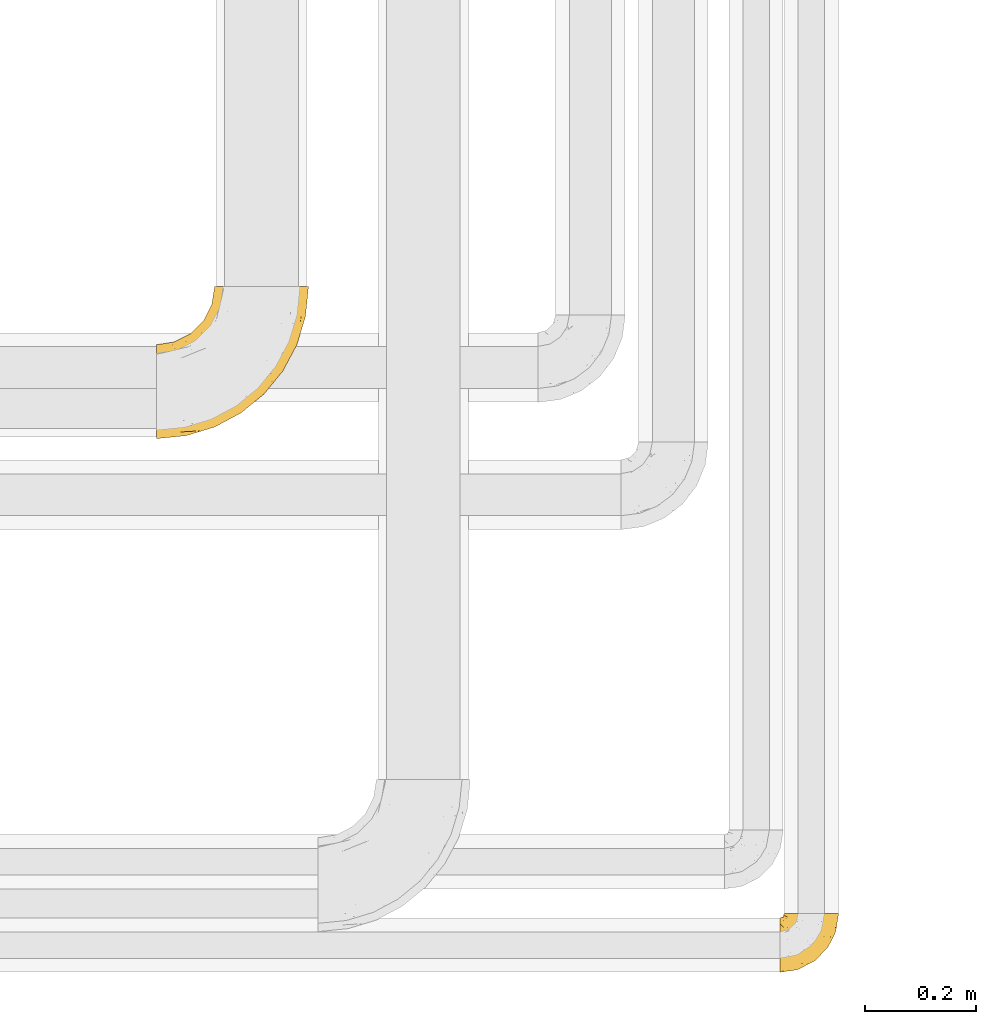
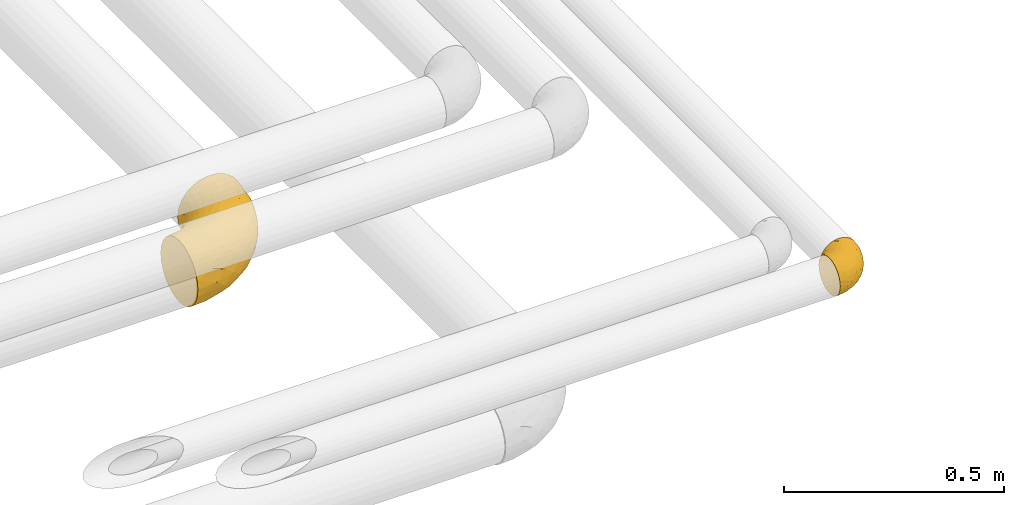
# One storey, part 487 of 827: 2 coverings.
"""IFC2X3 building model written with IfcOpenShell, lengths in millimetres."""

from ifc_helpers import new_model, entity, si_unit, converted_unit, derived_unit, direction, frame, origin, place, context, subcontext, project, spatial, faceted_brep, element, save


model = new_model("IFC2X3")

# Units and contexts
model_context = context("Model", 3, precision=0.01, world=origin(), true_north=direction((6.12303176911189e-17, 1.0)))
body_context = subcontext(model_context, "Body", "Model", "MODEL_VIEW")
ifc_project = project(units=[si_unit("LENGTHUNIT", "METRE", prefix="MILLI"), si_unit("AREAUNIT", "SQUARE_METRE"), si_unit("VOLUMEUNIT", "CUBIC_METRE"), converted_unit("PLANEANGLEUNIT", "DEGREE", entity("IfcRatioMeasure", 0.0174532925199433), si_unit("PLANEANGLEUNIT", "RADIAN"), dimensions=[0, 0, 0, 0, 0, 0, 0]), si_unit("MASSUNIT", "GRAM", prefix="KILO"), derived_unit("MASSDENSITYUNIT", [(si_unit("MASSUNIT", "GRAM", prefix="KILO"), 1), (si_unit("LENGTHUNIT", "METRE"), -3)]), derived_unit("MOMENTOFINERTIAUNIT", [(si_unit("LENGTHUNIT", "METRE"), 4)]), si_unit("TIMEUNIT", "SECOND"), si_unit("FREQUENCYUNIT", "HERTZ"), si_unit("THERMODYNAMICTEMPERATUREUNIT", "DEGREE_CELSIUS"), derived_unit("THERMALTRANSMITTANCEUNIT", [(si_unit("MASSUNIT", "GRAM", prefix="KILO"), 1), (si_unit("THERMODYNAMICTEMPERATUREUNIT", "KELVIN"), -1), (si_unit("TIMEUNIT", "SECOND"), -3)]), derived_unit("VOLUMETRICFLOWRATEUNIT", [(si_unit("LENGTHUNIT", "METRE"), 3), (si_unit("TIMEUNIT", "SECOND"), -1)]), derived_unit("MASSFLOWRATEUNIT", [(si_unit("MASSUNIT", "GRAM", prefix="KILO"), 1), (si_unit("TIMEUNIT", "SECOND"), -1)]), derived_unit("ROTATIONALFREQUENCYUNIT", [(si_unit("TIMEUNIT", "SECOND"), -1)]), si_unit("ELECTRICCURRENTUNIT", "AMPERE"), si_unit("ELECTRICVOLTAGEUNIT", "VOLT"), si_unit("POWERUNIT", "WATT"), si_unit("FORCEUNIT", "NEWTON", prefix="KILO"), si_unit("ILLUMINANCEUNIT", "LUX"), si_unit("LUMINOUSFLUXUNIT", "LUMEN"), si_unit("LUMINOUSINTENSITYUNIT", "CANDELA"), derived_unit("USERDEFINED", [(si_unit("MASSUNIT", "GRAM", prefix="KILO"), -1), (si_unit("LENGTHUNIT", "METRE"), -2), (si_unit("TIMEUNIT", "SECOND"), 3), (si_unit("LUMINOUSFLUXUNIT", "LUMEN"), 1)]), derived_unit("LINEARVELOCITYUNIT", [(si_unit("LENGTHUNIT", "METRE"), 1), (si_unit("TIMEUNIT", "SECOND"), -1)]), si_unit("PRESSUREUNIT", "PASCAL"), derived_unit("USERDEFINED", [(si_unit("LENGTHUNIT", "METRE"), -2), (si_unit("MASSUNIT", "GRAM", prefix="KILO"), 1), (si_unit("TIMEUNIT", "SECOND"), -2)]), derived_unit("LINEARFORCEUNIT", [(si_unit("MASSUNIT", "GRAM", prefix="KILO"), 1), (si_unit("LENGTHUNIT", "METRE"), 1), (si_unit("TIMEUNIT", "SECOND"), -2), (si_unit("LENGTHUNIT", "METRE"), -1)]), derived_unit("PLANARFORCEUNIT", [(si_unit("MASSUNIT", "GRAM", prefix="KILO"), 1), (si_unit("LENGTHUNIT", "METRE"), 1), (si_unit("TIMEUNIT", "SECOND"), -2), (si_unit("LENGTHUNIT", "METRE"), -2)])], contexts=[model_context])

# Site, building, storey
site_placement = place(None, origin())
site = spatial("IfcSite", under=ifc_project, at=site_placement, CompositionType="ELEMENT")
building_placement = place(site_placement, origin())
building = spatial("IfcBuilding", under=site, at=building_placement, CompositionType="ELEMENT")
storey_placement = place(building_placement, frame((0.0, 0.0, 28200.0)))
storey = spatial("IfcBuildingStorey", under=building, at=storey_placement, Name="08", CompositionType="ELEMENT", Elevation=28200.0)

# Coverings
covering_1_placement = place(storey_placement, frame((61094.04, 6214.96, 3049.25)))
element("IfcCovering", 1, at=covering_1_placement, inside=storey, Name=":ADSK_", ObjectType=":ADSK_", PredefinedType="INSULATION", context=body_context, shape_type="Brep", body=[
    faceted_brep([(58.6, 107.75, 99.9), (69.54, 107.75, 98.66), (79.93, 107.75, 95.02), (89.25, 107.75, 89.17), (97.03, 107.75, 81.38), (102.88, 107.75, 72.06), (106.51, 107.75, 61.68), (107.75, 107.75, 50.75), (106.51, 107.75, 39.8), (102.87, 107.75, 29.41), (97.02, 107.75, 20.09), (89.23, 107.75, 12.31), (79.91, 107.75, 6.46), (69.53, 107.75, 2.83), (58.6, 107.75, 1.6), (52.89, 107.75, 2.24), (47.65, 107.75, 2.83), (42.46, 107.75, 4.65), (37.26, 107.75, 6.47), (27.94, 107.75, 12.32), (20.16, 107.75, 20.11), (14.31, 107.75, 29.43), (10.68, 107.75, 39.81), (9.45, 107.75, 50.75), (10.68, 107.75, 61.69), (14.32, 107.75, 72.08), (20.17, 107.75, 81.4), (27.96, 107.75, 89.18), (37.28, 107.75, 95.03), (42.47, 107.75, 96.85), (47.66, 107.75, 98.66), (52.89, 107.75, 99.25), (55.75, 107.75, 99.57), (1.6, 98.22, 38.02), (1.6, 93.31, 26.17), (1.6, 89.4, 21.08), (1.6, 85.5, 15.99), (1.6, 80.41, 12.09), (1.6, 75.32, 8.18), (1.6, 69.39, 5.73), (1.6, 63.47, 3.27), (1.6, 56.48, 2.35), (1.6, 53.61, 1.97), (1.6, 50.75, 1.6), (1.6, 38.02, 3.27), (1.6, 26.17, 8.18), (1.6, 15.99, 15.99), (1.6, 8.18, 26.17), (1.6, 3.27, 38.02), (1.6, 1.6, 50.75), (1.6, 3.27, 63.47), (1.6, 8.18, 75.32), (1.6, 15.99, 85.5), (1.6, 26.17, 93.31), (1.6, 38.02, 98.22), (1.6, 50.75, 99.9), (1.6, 56.48, 99.14), (1.6, 63.47, 98.22), (1.6, 69.39, 95.77), (1.6, 75.32, 93.31), (1.6, 80.41, 89.4), (1.6, 85.5, 85.5), (1.6, 89.4, 80.41), (1.6, 93.31, 75.32), (1.6, 98.22, 63.47), (1.6, 99.9, 50.75), (69.96, 27.53, 59.31), (59.59, 25.32, 73.08), (51.96, 16.29, 63.72), (34.4, 6.79, 50.75), (23.37, 4.51, 58.64), (13.68, 3.51, 50.75), (41.52, 17.47, 76.74), (26.26, 7.6, 67.68), (20.18, 12.27, 78.92), (72.33, 70.89, 94.31), (65.88, 87.17, 98.76), (57.55, 67.3, 98.4), (23.76, 31.65, 94.57), (46.5, 33.58, 89.91), (46.57, 47.23, 96.32), (21.17, 43.26, 98.79), (23.41, 55.08, 99.9), (17.92, 53.99, 99.9), (12.43, 52.9, 99.9), (9.72, 52.36, 99.9), (7.01, 51.82, 99.9), (26.77, 21.5, 87.31), (76.59, 89.94, 95.61), (95.55, 60.45, 60.43), (102.57, 83.0, 65.24), (92.89, 64.79, 72.87), (54.26, 85.93, 99.9), (51.17, 81.31, 99.9), (48.08, 76.69, 99.9), (44.99, 72.06, 99.9), (41.9, 67.44, 99.9), (85.16, 88.74, 90.65), (85.97, 45.98, 63.14), (59.58, 47.13, 91.89), (99.5, 89.4, 75.25), (105.83, 95.66, 50.75), (53.59, 28.5, 82.18), (67.0, 42.81, 85.08), (71.56, 38.28, 76.93), (87.47, 45.35, 50.75), (75.73, 33.61, 50.75), (92.24, 82.57, 83.02), (58.06, 105.04, 99.9), (57.52, 102.33, 99.9), (56.44, 96.91, 99.9), (55.35, 91.42, 99.9), (81.33, 65.92, 87.13), (80.35, 53.11, 80.85), (39.44, 54.37, 99.17), (102.55, 74.94, 50.75), (37.28, 64.35, 99.9), (32.65, 61.26, 99.9), (28.03, 58.17, 99.9), (63.99, 21.87, 50.75), (74.55, 34.79, 67.61), (83.62, 48.48, 72.25), (95.01, 60.15, 50.75), (49.19, 14.33, 50.75), (46.96, 99.07, 98.69), (8.77, 60.55, 99.01), (18.28, 64.18, 98.79), (11.68, 64.36, 98.29), (11.79, 103.17, 68.51), (15.69, 101.69, 76.82), (42.49, 87.75, 98.54), (47.41, 89.38, 99.3), (7.94, 88.34, 83.57), (9.27, 82.14, 89.47), (7.98, 94.51, 75.76), (13.4, 89.64, 84.86), (13.04, 98.41, 75.89), (7.36, 99.71, 64.77), (23.46, 89.37, 90.83), (30.46, 88.21, 94.62), (26.54, 95.2, 90.37), (6.76, 79.14, 91.18), (26.46, 101.22, 88.65), (20.77, 99.41, 84.11), (20.68, 84.72, 91.75), (40.26, 97.47, 96.86), (7.15, 102.19, 50.75), (9.28, 104.02, 58.97), (38.78, 82.66, 98.37), (18.27, 95.42, 83.91), (31.78, 78.67, 97.52), (12.75, 72.69, 95.55), (22.96, 66.46, 98.76), (17.55, 75.3, 95.26), (27.63, 72.74, 98.04), (15.23, 82.93, 90.65), (33.25, 99.27, 93.51), (32.43, 93.51, 94.16), (27.9, 67.35, 99.1), (7.97, 94.51, 25.73), (15.22, 82.94, 10.84), (7.93, 88.33, 17.92), (13.38, 89.64, 16.64), (13.12, 103.62, 30.44), (42.49, 87.74, 2.95), (47.4, 89.38, 2.19), (51.17, 81.31, 1.6), (40.24, 97.47, 4.63), (20.76, 99.41, 17.39), (12.43, 52.9, 1.6), (7.01, 51.82, 1.6), (4.31, 51.28, 1.6), (26.44, 101.21, 12.86), (26.52, 95.19, 11.13), (11.68, 64.36, 3.2), (12.75, 72.69, 5.94), (9.27, 82.13, 12.02), (17.55, 75.3, 6.23), (6.76, 79.14, 10.31), (33.21, 99.28, 8.0), (32.41, 93.51, 7.34), (8.77, 60.55, 2.48), (22.96, 66.46, 2.73), (18.48, 63.96, 2.64), (56.44, 96.91, 1.6), (46.95, 99.06, 2.8), (7.36, 99.7, 36.71), (17.92, 53.99, 1.6), (23.41, 55.08, 1.6), (9.85, 103.3, 38.59), (57.52, 102.33, 1.6), (56.98, 99.62, 1.6), (48.08, 76.69, 1.6), (38.78, 82.66, 3.12), (18.25, 95.42, 17.59), (44.99, 72.06, 1.6), (31.74, 78.68, 3.98), (30.45, 88.2, 6.87), (27.63, 72.75, 3.45), (20.65, 84.74, 9.76), (55.35, 91.42, 1.6), (54.26, 85.93, 1.6), (13.03, 98.41, 25.62), (23.44, 89.37, 10.67), (27.9, 67.35, 2.39), (32.65, 61.26, 1.6), (28.03, 58.17, 1.6), (37.28, 64.35, 1.6), (41.9, 67.44, 1.6), (39.74, 54.08, 2.4), (23.37, 4.51, 42.85), (26.77, 21.5, 14.18), (46.18, 33.43, 11.56), (53.54, 28.5, 19.27), (41.53, 17.47, 24.75), (59.61, 25.36, 28.37), (76.79, 90.18, 5.95), (66.11, 86.97, 2.79), (21.17, 43.26, 2.71), (51.96, 16.29, 37.78), (26.26, 7.6, 33.81), (20.18, 12.27, 22.57), (23.76, 31.65, 6.92), (92.88, 64.79, 28.61), (102.57, 83.0, 36.24), (95.54, 60.44, 41.05), (71.63, 38.35, 24.55), (74.55, 34.8, 33.88), (72.51, 71.54, 7.11), (69.96, 27.53, 42.18), (92.23, 82.57, 18.46), (85.15, 88.74, 10.84), (80.45, 53.19, 20.69), (83.65, 48.49, 29.27), (57.57, 67.28, 3.1), (63.68, 52.32, 9.18), (85.95, 45.94, 38.38), (99.49, 89.4, 26.23), (81.23, 65.75, 14.34), (47.07, 46.73, 5.46), (66.99, 42.82, 16.39)], [[[0, 1, 2, 3, 4, 5, 6, 7, 8, 9, 10, 11, 12, 13, 14, 15, 16, 17, 18, 19, 20, 21, 22, 23, 24, 25, 26, 27, 28, 29, 30, 31, 32]], [[33, 34, 35, 36, 37, 38, 39, 40, 41, 42, 43, 44, 45, 46, 47, 48, 49, 50, 51, 52, 53, 54, 55, 56, 57, 58, 59, 60, 61, 62, 63, 64, 65]], [[66, 67, 68]], [[69, 70, 71]], [[68, 72, 73]], [[73, 72, 74]], [[75, 76, 77]], [[78, 79, 80]], [[51, 50, 73]], [[81, 82, 83, 84, 85, 86, 55]], [[52, 87, 53]], [[74, 52, 51]], [[2, 1, 88]], [[89, 90, 91]], [[77, 92, 93, 94, 95, 96]], [[55, 54, 81]], [[78, 53, 87]], [[5, 90, 6]], [[88, 76, 75]], [[97, 3, 2]], [[89, 91, 98]], [[99, 80, 79]], [[90, 5, 100]], [[74, 87, 52]], [[100, 5, 4]], [[90, 101, 6]], [[79, 102, 103]], [[102, 67, 104]], [[105, 98, 106]], [[107, 4, 3]], [[76, 0, 108, 109, 110, 111, 92]], [[107, 112, 113]], [[114, 77, 96]], [[89, 115, 90]], [[114, 96, 116, 117, 118, 82]], [[75, 97, 88]], [[119, 66, 68]], [[50, 71, 70]], [[100, 91, 90]], [[99, 77, 80]], [[102, 104, 103]], [[97, 107, 3]], [[80, 81, 78]], [[107, 97, 112]], [[68, 73, 70]], [[66, 98, 120]], [[78, 81, 54]], [[114, 81, 80]], [[53, 78, 54]], [[78, 87, 79]], [[102, 87, 72]], [[79, 103, 99]], [[4, 107, 100]], [[91, 100, 107]], [[88, 97, 2]], [[112, 97, 75]], [[99, 112, 75]], [[103, 104, 113]], [[91, 121, 98]], [[89, 105, 122, 115]], [[101, 90, 115]], [[101, 7, 6]], [[88, 1, 76]], [[0, 76, 1]], [[92, 77, 76]], [[73, 74, 51]], [[87, 74, 72]], [[81, 114, 82]], [[77, 114, 80]], [[87, 102, 79]], [[67, 102, 72]], [[68, 67, 72]], [[67, 120, 104]], [[120, 121, 104]], [[104, 121, 113]], [[121, 120, 98]], [[91, 107, 113]], [[91, 113, 121]], [[103, 113, 112]], [[106, 98, 66]], [[105, 89, 98]], [[106, 66, 119]], [[67, 66, 120]], [[68, 69, 123, 119]], [[50, 49, 71]], [[50, 70, 73]], [[112, 99, 103]], [[77, 99, 75]], [[69, 68, 70]], [[29, 124, 110]], [[84, 83, 125]], [[126, 82, 118]], [[59, 58, 127]], [[25, 128, 129]], [[130, 93, 131]], [[132, 62, 133]], [[134, 135, 136]], [[137, 65, 64]], [[64, 134, 137]], [[138, 139, 140]], [[111, 110, 124, 92]], [[134, 136, 137]], [[134, 64, 63]], [[141, 61, 60]], [[125, 58, 57]], [[142, 143, 140]], [[142, 26, 143]], [[127, 83, 82]], [[28, 124, 29]], [[108, 0, 32, 31, 30, 110, 109]], [[30, 29, 110]], [[135, 144, 138]], [[28, 145, 124]], [[57, 56, 55, 86, 85, 84]], [[146, 147, 23]], [[24, 23, 147]], [[25, 143, 26]], [[95, 94, 148]], [[24, 128, 25]], [[149, 138, 143]], [[124, 145, 131]], [[127, 58, 125]], [[150, 148, 139]], [[127, 126, 151]], [[151, 59, 127]], [[152, 151, 126]], [[153, 154, 155]], [[153, 133, 141]], [[145, 28, 27]], [[142, 156, 27]], [[157, 148, 130]], [[61, 133, 62]], [[134, 132, 135]], [[147, 128, 24]], [[65, 137, 146]], [[146, 137, 147]], [[128, 137, 136]], [[137, 128, 147]], [[128, 136, 129]], [[149, 129, 136]], [[25, 129, 143]], [[158, 152, 117]], [[152, 118, 117]], [[153, 151, 152]], [[158, 116, 154]], [[144, 150, 138]], [[153, 152, 158]], [[133, 153, 155]], [[133, 155, 132]], [[60, 151, 141]], [[135, 132, 155]], [[134, 63, 132]], [[144, 135, 155]], [[135, 138, 149]], [[155, 154, 144]], [[150, 154, 96]], [[154, 150, 144]], [[148, 94, 130]], [[82, 126, 127]], [[118, 152, 126]], [[150, 96, 95]], [[139, 148, 157]], [[150, 95, 148]], [[93, 92, 131]], [[130, 145, 156]], [[130, 94, 93]], [[84, 125, 57]], [[127, 125, 83]], [[140, 139, 157]], [[150, 139, 138]], [[140, 157, 142]], [[138, 140, 143]], [[156, 142, 157]], [[27, 26, 142]], [[130, 156, 157]], [[145, 27, 156]], [[132, 63, 62]], [[124, 131, 92]], [[130, 131, 145]], [[129, 149, 143]], [[135, 149, 136]], [[141, 133, 61]], [[60, 59, 151]], [[141, 151, 153]], [[116, 96, 154]], [[153, 158, 154]], [[158, 117, 116]], [[34, 33, 159]], [[160, 161, 162]], [[22, 21, 163]], [[164, 165, 166]], [[19, 18, 167]], [[168, 21, 20]], [[42, 41, 40, 169, 170, 171, 43]], [[172, 173, 168]], [[174, 38, 175]], [[176, 177, 178]], [[179, 164, 180]], [[40, 181, 169]], [[182, 183, 175]], [[17, 184, 185]], [[65, 146, 186]], [[187, 174, 188]], [[23, 22, 189]], [[174, 39, 38]], [[15, 14, 190, 191, 184, 16]], [[181, 40, 39]], [[192, 193, 164]], [[194, 163, 168]], [[33, 186, 159]], [[180, 173, 172]], [[195, 196, 193]], [[18, 185, 167]], [[173, 180, 197]], [[198, 199, 196]], [[200, 201, 185, 184]], [[184, 17, 16]], [[18, 17, 185]], [[202, 159, 186]], [[194, 168, 203]], [[189, 163, 202]], [[204, 205, 182]], [[187, 181, 174]], [[160, 177, 176]], [[206, 183, 182]], [[206, 182, 205]], [[201, 165, 185]], [[165, 164, 167]], [[172, 179, 180]], [[202, 194, 162]], [[176, 161, 160]], [[65, 186, 33]], [[163, 189, 22]], [[175, 177, 182]], [[174, 183, 188]], [[177, 198, 204]], [[199, 160, 162]], [[198, 207, 204]], [[175, 38, 37]], [[198, 177, 160]], [[178, 177, 175]], [[176, 35, 161]], [[34, 159, 161]], [[162, 161, 159]], [[202, 162, 159]], [[199, 162, 203]], [[196, 199, 203]], [[198, 160, 199]], [[193, 197, 180]], [[208, 198, 196]], [[188, 183, 206]], [[175, 183, 174]], [[193, 192, 195]], [[195, 208, 196]], [[197, 196, 203]], [[180, 164, 193]], [[168, 163, 21]], [[166, 165, 201]], [[166, 192, 164]], [[189, 202, 186]], [[186, 146, 189]], [[23, 189, 146]], [[174, 181, 39]], [[169, 181, 187]], [[196, 197, 193]], [[173, 203, 168]], [[203, 173, 197]], [[172, 168, 20]], [[20, 19, 172]], [[179, 172, 19]], [[19, 167, 179]], [[164, 179, 167]], [[35, 176, 36]], [[35, 34, 161]], [[185, 165, 167]], [[162, 194, 203]], [[163, 194, 202]], [[176, 178, 36]], [[37, 36, 178]], [[175, 37, 178]], [[177, 204, 182]], [[207, 198, 208]], [[207, 205, 204]], [[209, 188, 206, 205, 207, 208]], [[48, 210, 71]], [[211, 212, 213]], [[214, 213, 215]], [[216, 217, 13]], [[218, 43, 171, 170, 169, 187, 188]], [[219, 220, 214]], [[47, 46, 221]], [[210, 48, 220]], [[211, 222, 212]], [[222, 45, 44]], [[221, 220, 47]], [[47, 220, 48]], [[221, 211, 214]], [[223, 224, 225]], [[211, 46, 45]], [[226, 227, 215]], [[43, 218, 44]], [[217, 216, 228]], [[219, 215, 229]], [[14, 13, 217]], [[224, 9, 8]], [[10, 230, 11]], [[11, 231, 12]], [[232, 223, 233]], [[234, 208, 195, 192, 166, 201]], [[235, 234, 228]], [[222, 44, 218]], [[106, 229, 236]], [[224, 237, 9]], [[231, 238, 228]], [[9, 237, 10]], [[115, 224, 101]], [[239, 234, 235]], [[231, 11, 230]], [[223, 230, 237]], [[224, 8, 101]], [[223, 236, 233]], [[225, 115, 122, 105]], [[216, 12, 231]], [[209, 234, 239]], [[210, 219, 69]], [[219, 214, 215]], [[229, 119, 219]], [[209, 218, 188]], [[239, 212, 222]], [[239, 222, 218]], [[45, 222, 211]], [[235, 212, 239]], [[213, 212, 240]], [[223, 237, 224]], [[230, 10, 237]], [[238, 231, 230]], [[216, 231, 228]], [[232, 230, 223]], [[235, 238, 240]], [[115, 225, 224]], [[233, 236, 227]], [[8, 7, 101]], [[234, 209, 208]], [[218, 209, 239]], [[217, 228, 234]], [[13, 12, 216]], [[234, 201, 217]], [[217, 201, 200, 184, 191, 190, 14]], [[211, 221, 46]], [[220, 221, 214]], [[71, 210, 69]], [[71, 49, 48]], [[219, 210, 220]], [[226, 215, 213]], [[211, 213, 214]], [[226, 213, 240]], [[215, 227, 229]], [[232, 240, 238]], [[233, 227, 226]], [[232, 233, 226]], [[236, 223, 225]], [[240, 232, 226]], [[232, 238, 230]], [[225, 105, 236]], [[236, 105, 106]], [[236, 229, 227]], [[123, 69, 219, 119]], [[106, 119, 229]], [[238, 235, 228]], [[212, 235, 240]]]),
])
covering_2_placement = place(storey_placement, frame((59966.95, 7179.76, 2813.52)))
element("IfcCovering", 2, at=covering_2_placement, inside=storey, Name=":ADSK_", ObjectType=":ADSK_", PredefinedType="INSULATION", context=body_context, shape_type="Brep", body=[
    faceted_brep([(220.62, 276.45, 166.18), (234.03, 276.45, 159.93), (246.14, 276.45, 151.44), (256.6, 276.45, 140.98), (265.08, 276.45, 128.87), (271.33, 276.45, 115.47), (275.16, 276.45, 101.18), (276.45, 276.45, 86.45), (275.16, 276.45, 71.71), (271.33, 276.45, 57.42), (265.08, 276.45, 44.02), (256.59, 276.45, 31.9), (246.13, 276.45, 21.45), (234.02, 276.45, 12.96), (220.62, 276.45, 6.71), (206.33, 276.45, 2.89), (191.6, 276.45, 1.6), (176.86, 276.45, 2.89), (162.57, 276.45, 6.71), (149.17, 276.45, 12.97), (137.05, 276.45, 21.45), (126.6, 276.45, 31.91), (118.11, 276.45, 44.02), (111.86, 276.45, 57.42), (108.04, 276.45, 71.71), (106.75, 276.45, 86.45), (108.04, 276.45, 101.18), (111.86, 276.45, 115.47), (118.12, 276.45, 128.88), (126.6, 276.45, 140.99), (137.06, 276.45, 151.45), (149.17, 276.45, 159.93), (162.57, 276.45, 166.18), (176.86, 276.45, 170.01), (191.6, 276.45, 171.3), (206.33, 276.45, 170.01), (1.6, 146.44, 26.45), (1.6, 128.87, 12.96), (1.6, 108.41, 4.49), (1.6, 86.45, 1.6), (1.6, 64.48, 4.49), (1.6, 44.02, 12.96), (1.6, 26.45, 26.45), (1.6, 12.96, 44.02), (1.6, 4.49, 64.48), (1.6, 1.6, 86.45), (1.6, 4.49, 108.41), (1.6, 12.96, 128.87), (1.6, 26.45, 146.44), (1.6, 44.02, 159.93), (1.6, 64.48, 168.4), (1.6, 86.45, 171.3), (1.6, 108.41, 168.4), (1.6, 128.87, 159.93), (1.6, 146.44, 146.44), (1.6, 159.93, 128.87), (1.6, 168.4, 108.41), (1.6, 171.3, 86.45), (1.6, 168.4, 64.48), (1.6, 159.93, 44.02), (78.36, 15.68, 108.89), (55.22, 6.88, 86.45), (106.78, 22.52, 86.45), (227.56, 227.06, 160.57), (210.93, 105.43, 113.84), (166.54, 74.07, 132.78), (169.48, 65.28, 115.35), (195.94, 82.1, 86.45), (121.35, 108.1, 169.66), (150.14, 157.98, 171.3), (135.1, 142.94, 171.3), (120.06, 127.9, 171.3), (124.32, 40.39, 124.06), (130.67, 36.41, 106.11), (210.57, 219.38, 167.01), (93.72, 48.08, 149.97), (139.64, 66.33, 145.0), (144.17, 85.3, 156.09), (154.29, 47.92, 86.45), (208.4, 119.45, 134.92), (240.3, 167.65, 130.81), (221.79, 158.93, 146.85), (230.13, 123.75, 86.45), (262.33, 215.32, 120.3), (248.26, 166.87, 114.99), (263.49, 198.48, 102.82), (63.94, 24.94, 135.66), (108.29, 42.19, 137.97), (79.35, 82.38, 169.13), (42.69, 36.25, 152.15), (271.16, 222.82, 86.45), (255.52, 171.26, 86.45), (76.62, 60.65, 162.08), (212.49, 178.29, 159.82), (49.07, 13.85, 122.41), (126.68, 91.93, 164.65), (177.19, 124.79, 160.16), (177.64, 100.4, 147.46), (179.24, 158.16, 168.0), (84.03, 105.26, 171.3), (172.78, 194.01, 171.3), (246.43, 215.15, 143.95), (43.87, 91.21, 171.3), (186.83, 234.17, 171.3), (35.25, 164.99, 128.7), (55.06, 177.54, 120.84), (29.98, 171.18, 111.79), (40.1, 114.41, 167.99), (174.11, 252.37, 169.81), (141.82, 215.13, 162.83), (151.41, 186.9, 169.87), (162.23, 211.59, 169.62), (68.19, 171.79, 139.83), (78.22, 160.7, 154.11), (94.43, 183.61, 147.71), (83.32, 192.61, 129.83), (106.07, 245.89, 111.24), (95.5, 220.22, 113.13), (105.97, 225.17, 128.47), (106.13, 142.35, 168.91), (90.7, 150.8, 163.29), (84.2, 127.23, 169.04), (63.4, 191.38, 86.45), (50.79, 181.8, 102.42), (78.07, 199.97, 108.81), (30.53, 135.99, 157.36), (42.81, 156.0, 143.61), (119.66, 206.47, 152.91), (127.3, 189.29, 162.79), (101.6, 243.95, 86.45), (86.66, 214.64, 86.45), (132.44, 160.81, 169.89), (118.77, 234.66, 140.27), (113.91, 251.09, 126.4), (34.09, 176.44, 86.45), (114.56, 163.48, 165.72), (159.75, 239.19, 166.71), (108.44, 210.92, 141.38), (145.49, 249.94, 159.19), (101.13, 171.53, 158.14), (131.96, 241.26, 151.08), (64.62, 140.54, 161.17), (78.07, 199.97, 64.08), (43.87, 91.21, 1.6), (40.1, 114.41, 4.9), (84.03, 105.26, 1.6), (29.98, 171.18, 61.1), (50.79, 181.8, 70.47), (174.1, 252.37, 3.08), (55.06, 177.54, 52.05), (35.25, 164.99, 44.19), (95.5, 220.22, 59.77), (83.31, 192.61, 43.07), (68.19, 171.79, 33.07), (105.97, 225.18, 44.43), (108.44, 210.92, 31.51), (30.54, 135.99, 15.53), (42.81, 156.0, 29.28), (64.63, 140.54, 11.72), (106.07, 245.9, 61.65), (84.21, 127.24, 3.85), (120.06, 127.9, 1.6), (162.23, 211.59, 3.27), (186.83, 234.17, 1.6), (172.78, 194.01, 1.6), (119.66, 206.47, 19.99), (131.95, 241.25, 21.82), (141.81, 215.12, 10.07), (113.91, 251.09, 46.5), (127.29, 189.29, 10.11), (145.35, 242.44, 12.88), (118.77, 234.66, 32.63), (90.7, 150.81, 9.6), (106.13, 142.36, 3.98), (135.1, 142.94, 1.6), (78.22, 160.71, 18.78), (159.75, 239.18, 6.18), (151.41, 186.9, 3.02), (150.14, 157.98, 1.6), (132.44, 160.81, 3.0), (114.56, 163.49, 7.17), (101.13, 171.54, 14.75), (94.43, 183.61, 25.19), (79.36, 82.38, 3.76), (121.35, 108.1, 3.23), (126.68, 91.93, 8.24), (78.36, 15.68, 64.0), (210.57, 219.38, 5.88), (212.49, 178.29, 13.07), (177.18, 124.78, 12.73), (179.23, 158.16, 4.89), (221.79, 158.93, 26.04), (169.48, 65.28, 57.54), (76.63, 60.65, 10.82), (82.71, 22.53, 49.86), (63.94, 24.94, 37.23), (108.29, 42.19, 34.92), (42.69, 36.25, 20.74), (93.72, 48.08, 22.92), (210.93, 105.43, 59.05), (248.25, 166.87, 57.9), (177.64, 100.4, 25.44), (208.4, 119.46, 37.97), (124.32, 40.39, 48.83), (130.67, 36.41, 66.78), (139.64, 66.33, 27.89), (262.33, 215.32, 52.59), (166.55, 74.07, 40.11), (246.43, 215.16, 28.94), (227.55, 227.05, 12.32), (144.16, 85.29, 16.8), (263.49, 198.48, 70.07), (240.3, 167.65, 42.08)], [[[0, 1, 2, 3, 4, 5, 6, 7, 8, 9, 10, 11, 12, 13, 14, 15, 16, 17, 18, 19, 20, 21, 22, 23, 24, 25, 26, 27, 28, 29, 30, 31, 32, 33, 34, 35]], [[36, 37, 38, 39, 40, 41, 42, 43, 44, 45, 46, 47, 48, 49, 50, 51, 52, 53, 54, 55, 56, 57, 58, 59]], [[60, 61, 62]], [[61, 46, 45]], [[63, 2, 1]], [[64, 65, 66]], [[64, 66, 67]], [[68, 69, 70, 71]], [[72, 73, 66]], [[74, 0, 35]], [[75, 76, 77]], [[78, 73, 62]], [[79, 80, 81]], [[64, 67, 82]], [[83, 84, 85]], [[86, 48, 47]], [[65, 76, 87]], [[51, 50, 88]], [[75, 89, 86]], [[90, 85, 91]], [[75, 77, 92]], [[74, 93, 63]], [[94, 46, 60]], [[95, 68, 88]], [[96, 97, 81]], [[96, 93, 98]], [[88, 68, 99]], [[98, 100, 69]], [[83, 101, 80]], [[101, 63, 81]], [[48, 89, 49]], [[79, 65, 64]], [[85, 6, 5]], [[101, 83, 3]], [[50, 92, 88]], [[83, 85, 5]], [[94, 86, 47]], [[3, 83, 4]], [[75, 87, 76]], [[90, 7, 6]], [[88, 99, 102]], [[101, 3, 2]], [[100, 98, 74]], [[100, 74, 103]], [[4, 83, 5]], [[34, 103, 35]], [[51, 88, 102]], [[85, 84, 91]], [[72, 86, 94]], [[81, 80, 101]], [[103, 74, 35]], [[98, 69, 68]], [[98, 93, 74]], [[74, 63, 0]], [[63, 101, 2]], [[50, 49, 92]], [[46, 61, 60]], [[84, 82, 91]], [[89, 92, 49]], [[95, 88, 92]], [[6, 85, 90]], [[83, 80, 84]], [[96, 81, 93]], [[79, 81, 97]], [[65, 79, 97]], [[64, 80, 79]], [[76, 65, 97]], [[65, 72, 66]], [[80, 64, 84]], [[82, 84, 64]], [[73, 72, 60]], [[67, 66, 78]], [[62, 73, 60]], [[78, 66, 73]], [[98, 95, 96]], [[77, 96, 95]], [[98, 68, 95]], [[99, 68, 71]], [[63, 93, 81]], [[0, 63, 1]], [[77, 76, 97]], [[75, 86, 87]], [[96, 77, 97]], [[77, 95, 92]], [[86, 72, 87]], [[65, 87, 72]], [[86, 89, 48]], [[92, 89, 75]], [[46, 94, 47]], [[72, 94, 60]], [[104, 105, 106]], [[52, 51, 102]], [[52, 102, 107]], [[33, 108, 103]], [[109, 110, 111]], [[112, 113, 114]], [[114, 115, 112]], [[99, 107, 102]], [[116, 117, 118]], [[119, 120, 121]], [[122, 123, 124]], [[53, 125, 54]], [[125, 126, 54]], [[127, 128, 109]], [[26, 129, 116]], [[130, 122, 124]], [[128, 131, 110]], [[57, 56, 106]], [[132, 28, 133]], [[106, 105, 123]], [[122, 134, 123]], [[135, 120, 119]], [[28, 132, 29]], [[121, 107, 99]], [[103, 108, 111]], [[107, 53, 52]], [[115, 124, 105]], [[136, 32, 31]], [[117, 129, 130]], [[34, 33, 103]], [[132, 137, 127]], [[136, 31, 138]], [[139, 114, 113]], [[32, 108, 33]], [[127, 114, 139]], [[30, 140, 138]], [[129, 26, 25]], [[133, 116, 118]], [[54, 126, 55]], [[126, 112, 104]], [[27, 26, 116]], [[116, 133, 27]], [[140, 30, 29]], [[117, 130, 124]], [[131, 119, 70]], [[109, 140, 127]], [[109, 136, 138]], [[118, 117, 115]], [[127, 140, 132]], [[110, 131, 69]], [[32, 136, 108]], [[125, 107, 141]], [[111, 108, 136]], [[105, 104, 112]], [[115, 114, 137]], [[107, 125, 53]], [[126, 125, 141]], [[105, 112, 115]], [[113, 126, 141]], [[126, 113, 112]], [[120, 113, 141]], [[134, 57, 106]], [[124, 123, 105]], [[134, 106, 123]], [[104, 56, 55]], [[56, 104, 106]], [[55, 126, 104]], [[120, 141, 121]], [[139, 120, 135]], [[107, 121, 141]], [[71, 121, 99]], [[121, 71, 119]], [[119, 71, 70]], [[131, 70, 69]], [[69, 100, 110]], [[119, 131, 135]], [[111, 110, 100]], [[110, 109, 128]], [[117, 116, 129]], [[115, 117, 124]], [[120, 139, 113]], [[139, 135, 128]], [[132, 133, 118]], [[27, 133, 28]], [[132, 118, 137]], [[29, 132, 140]], [[115, 137, 118]], [[114, 127, 137]], [[103, 111, 100]], [[109, 111, 136]], [[139, 128, 127]], [[128, 135, 131]], [[30, 138, 31]], [[109, 138, 140]], [[122, 130, 142]], [[143, 144, 145]], [[57, 134, 146]], [[146, 134, 147]], [[17, 148, 18]], [[149, 150, 146]], [[142, 149, 147]], [[122, 147, 134]], [[130, 129, 151]], [[150, 58, 146]], [[149, 152, 153]], [[154, 155, 152]], [[37, 144, 38]], [[39, 38, 143]], [[37, 36, 156]], [[156, 157, 158]], [[159, 154, 151]], [[144, 143, 38]], [[145, 160, 161]], [[36, 59, 157]], [[162, 163, 164]], [[165, 166, 167]], [[154, 159, 168]], [[162, 148, 163]], [[129, 25, 24]], [[169, 165, 167]], [[170, 20, 19]], [[168, 23, 22]], [[171, 21, 166]], [[160, 158, 172]], [[161, 173, 174]], [[165, 155, 171]], [[151, 129, 159]], [[20, 166, 21]], [[175, 172, 158]], [[170, 176, 167]], [[177, 178, 179]], [[179, 173, 180]], [[162, 164, 177]], [[152, 149, 142]], [[170, 167, 166]], [[171, 154, 168]], [[17, 16, 163]], [[129, 24, 159]], [[165, 169, 181]], [[17, 163, 148]], [[176, 19, 18]], [[153, 175, 157]], [[160, 144, 158]], [[23, 159, 24]], [[171, 155, 154]], [[156, 144, 37]], [[176, 18, 148]], [[152, 142, 151]], [[153, 152, 182]], [[157, 156, 36]], [[144, 156, 158]], [[175, 153, 182]], [[153, 157, 150]], [[181, 175, 182]], [[157, 175, 158]], [[142, 147, 122]], [[146, 147, 149]], [[153, 150, 149]], [[146, 58, 57]], [[157, 59, 150]], [[58, 150, 59]], [[181, 172, 175]], [[172, 173, 160]], [[172, 180, 173]], [[144, 160, 145]], [[174, 173, 179]], [[161, 160, 173]], [[174, 179, 178]], [[179, 169, 177]], [[178, 177, 164]], [[169, 179, 180]], [[162, 167, 176]], [[152, 151, 154]], [[130, 151, 142]], [[165, 181, 182]], [[172, 181, 180]], [[23, 168, 159]], [[22, 21, 171]], [[171, 168, 22]], [[165, 171, 166]], [[165, 182, 155]], [[152, 155, 182]], [[167, 162, 177]], [[162, 176, 148]], [[177, 169, 167]], [[181, 169, 180]], [[20, 170, 166]], [[19, 176, 170]], [[183, 184, 185]], [[43, 186, 44]], [[61, 44, 186]], [[183, 39, 143]], [[145, 161, 184]], [[62, 61, 186]], [[187, 164, 163]], [[188, 189, 190]], [[188, 191, 189]], [[178, 190, 184]], [[192, 67, 78]], [[193, 183, 185]], [[194, 43, 195]], [[195, 196, 194]], [[61, 45, 44]], [[40, 193, 41]], [[41, 197, 42]], [[197, 193, 198]], [[82, 199, 200]], [[201, 191, 202]], [[42, 197, 195]], [[203, 192, 204]], [[15, 187, 163]], [[62, 186, 204]], [[195, 43, 42]], [[190, 185, 184]], [[190, 178, 164]], [[196, 198, 205]], [[206, 10, 9]], [[205, 201, 207]], [[163, 16, 15]], [[14, 187, 15]], [[12, 208, 209]], [[39, 183, 40]], [[208, 12, 11]], [[205, 210, 201]], [[185, 210, 193]], [[13, 209, 14]], [[188, 190, 187]], [[206, 211, 200]], [[82, 67, 199]], [[208, 11, 206]], [[203, 207, 192]], [[90, 91, 211]], [[191, 188, 209]], [[206, 11, 10]], [[211, 8, 90]], [[9, 8, 211]], [[7, 90, 8]], [[191, 208, 212]], [[191, 209, 208]], [[208, 206, 212]], [[200, 212, 206]], [[145, 183, 143]], [[193, 40, 183]], [[188, 187, 209]], [[187, 190, 164]], [[202, 207, 201]], [[91, 82, 200]], [[211, 206, 9]], [[202, 191, 212]], [[189, 191, 201]], [[212, 199, 202]], [[199, 192, 207]], [[199, 207, 202]], [[195, 198, 196]], [[200, 211, 91]], [[199, 212, 200]], [[67, 192, 199]], [[204, 186, 194]], [[192, 78, 204]], [[62, 204, 78]], [[210, 189, 201]], [[185, 190, 189]], [[145, 184, 183]], [[184, 161, 174, 178]], [[14, 209, 187]], [[209, 13, 12]], [[196, 207, 203]], [[198, 193, 210]], [[198, 210, 205]], [[189, 210, 185]], [[207, 196, 205]], [[194, 196, 203]], [[193, 197, 41]], [[195, 197, 198]], [[204, 194, 203]], [[43, 194, 186]]]),
])

save(model, "model.ifc")
